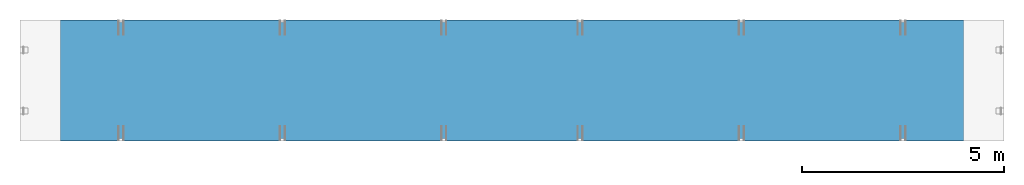
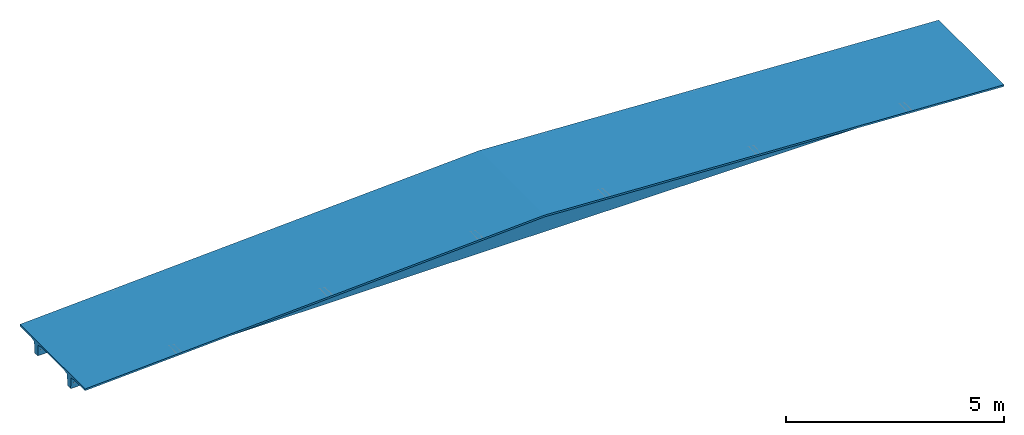
# One storey, part 8 of 8: 1 beam.
"""IFC2X3 building model written with IfcOpenShell, lengths in millimetres."""

from ifc_helpers import new_model, si_unit, frame, origin_with_axes, place, context, subcontext, project, spatial, faceted_brep, material, type_object, element, save


model = new_model("IFC2X3")

# Units and contexts
model_context = context("Model", 3, precision=1e-05, world=origin_with_axes())
body_context = subcontext(model_context, "Body", "Model", "MODEL_VIEW")
ifc_project = project(units=[si_unit("LENGTHUNIT", "METRE", prefix="MILLI"), si_unit("AREAUNIT", "SQUARE_METRE"), si_unit("VOLUMEUNIT", "CUBIC_METRE"), si_unit("MASSUNIT", "GRAM", prefix="KILO"), si_unit("TIMEUNIT", "SECOND"), si_unit("PLANEANGLEUNIT", "RADIAN"), si_unit("SOLIDANGLEUNIT", "STERADIAN"), si_unit("THERMODYNAMICTEMPERATUREUNIT", "DEGREE_CELSIUS"), si_unit("LUMINOUSINTENSITYUNIT", "LUMEN")], contexts=[model_context])

# Site, building, storey
site_placement = place(None, origin_with_axes())
site = spatial("IfcSite", under=ifc_project, at=site_placement, CompositionType="ELEMENT")
building_placement = place(site_placement, origin_with_axes())
building = spatial("IfcBuilding", under=site, at=building_placement, Name="Undefined", CompositionType="ELEMENT")
storey_placement = place(building_placement, origin_with_axes())
storey = spatial("IfcBuildingStorey", under=building, at=storey_placement, Name="Undefined", CompositionType="ELEMENT", Elevation=0.0)

# Beam
ifc_material = material(Name="CONCRETE/Concrete_Undefined")
beam_type = type_object("IfcBeamType", Name="HTT391.25", PredefinedType="NOTDEFINED")
beam_placement = place(storey_placement, frame((5.27828387121526e-14, -3.27270430338636e-13, 500.0), z_axis=(0.0, 0.0, 1.0), x_axis=(1.0, 0.0, 0.0)))
element("IfcBeam", 1, at=beam_placement, inside=storey, type_object=beam_type, material=ifc_material, ObjectType="HTT391.25", context=body_context, shape_type="Brep", body=[
    faceted_brep([(90.8253175473053, 837.75, -343.75), (90.8253175473053, 674.25, -343.75), (86.2499999999998, 674.066987298108, -339.174682452695), (86.2499999999998, 837.933012701892, -339.174682452695), (79.9999999999998, 674.0, -337.5), (79.9999999999998, 838.0, -337.5), (73.7499999999998, 674.066987298108, -339.174682452695), (73.7499999999998, 837.933012701892, -339.174682452695), (69.1746824526943, 674.25, -343.75), (69.1746824526943, 837.75, -343.75), (67.4999999999998, 674.5, -350.0), (67.4999999999998, 837.5, -350.0), (69.1746824526943, 674.75, -356.25), (69.1746824526943, 837.25, -356.25), (73.7499999999998, 674.933012701892, -360.825317547306), (73.7499999999998, 837.066987298108, -360.825317547306), (79.9999999999998, 675.0, -362.5), (79.9999999999998, 837.0, -362.5), (86.2499999999998, 674.933012701892, -360.825317547306), (86.2499999999998, 837.066987298108, -360.825317547306), (90.8253175473053, 674.75, -356.25), (90.8253175473053, 837.25, -356.25), (92.4999999999998, 674.5, -350.0), (92.4999999999998, 837.5, -350.0), (12175.0, 680.5, -500.0), (12175.0, 831.5, -500.0), (24350.0, 831.5, -500.0), (24350.0, 680.5, -500.0), (0.0, 680.5, -500.0), (0.0, 831.5, -500.0), (0.0, 843.65, -196.25), (12175.0, 868.0, 412.5), (0.0, 993.65, -158.75), (12175.0, 1018.0, 450.0), (24350.0, 993.65, -158.75), (24350.0, 843.65, -196.25), (12175.0, 1495.0, 450.0), (24350.0, 1495.0, -158.75), (0.0, 1495.0, -158.75), (0.0, 1495.0, -108.75), (12175.0, 1495.0, 500.0), (24350.0, 1495.0, -108.75), (12175.0, -1495.0, 500.0), (24350.0, -1495.0, -108.75), (0.0, -1495.0, -108.75), (12175.0, -831.5, -500.0), (12175.0, -680.5, -500.0), (24350.0, -680.5, -500.0), (24350.0, -831.5, -500.0), (0.0, -831.5, -500.0), (0.0, -680.5, -500.0), (0.0, -518.35, -158.75), (0.0, 518.35, -158.75), (12175.0, 494.0, 450.0), (12175.0, -494.0, 450.0), (0.0, -668.35, -196.25), (12175.0, -644.0, 412.5), (86.2499999999998, -674.066987298108, -339.174682452695), (79.9999999999998, -674.0, -337.5), (73.7499999999998, -674.066987298108, -339.174682452695), (69.1746824526943, -674.25, -343.75), (67.4999999999998, -674.5, -350.0), (69.1746824526943, -674.75, -356.25), (73.7499999999998, -674.933012701892, -360.825317547306), (79.9999999999998, -675.0, -362.5), (86.2499999999998, -674.933012701892, -360.825317547306), (90.8253175473053, -674.75, -356.25), (92.4999999999998, -674.5, -350.0), (90.8253175473053, -674.25, -343.75), (86.2499999999998, -837.066987298108, -360.825317547306), (90.8253175473053, -837.25, -356.25), (79.9999999999998, -837.0, -362.5), (73.7499999999998, -837.066987298108, -360.825317547306), (69.1746824526943, -837.25, -356.25), (67.4999999999998, -837.5, -350.0), (69.1746824526943, -837.75, -343.75), (73.7499999999998, -837.933012701892, -339.174682452695), (79.9999999999998, -838.0, -337.5), (86.2499999999998, -837.933012701892, -339.174682452695), (90.8253175473053, -837.75, -343.75), (92.4999999999998, -837.5, -350.0), (0.0, -843.65, -196.25), (12175.0, -868.0, 412.5), (0.0, -993.65, -158.75), (12175.0, -1018.0, 450.0), (0.0, -1495.0, -158.75), (12175.0, -1495.0, 450.0), (0.0, 668.35, -196.25), (12175.0, 644.0, 412.5), (24350.0, 668.35, -196.25), (24350.0, 518.35, -158.75), (24350.0, -518.35, -158.75), (24350.0, -668.35, -196.25), (24276.25, -674.066987298108, -339.174682452695), (24270.0, -674.0, -337.5), (24263.75, -674.066987298108, -339.174682452695), (24259.1746824527, -674.25, -343.75), (24257.5, -674.5, -350.0), (24259.1746824527, -674.75, -356.25), (24263.75, -674.933012701892, -360.825317547306), (24270.0, -675.0, -362.5), (24276.25, -674.933012701892, -360.825317547306), (24280.8253175473, -674.75, -356.25), (24282.5, -674.5, -350.0), (24280.8253175473, -674.25, -343.75), (24276.25, -837.066987298108, -360.825317547306), (24280.8253175473, -837.25, -356.25), (24270.0, -837.0, -362.5), (24263.75, -837.066987298108, -360.825317547306), (24259.1746824527, -837.25, -356.25), (24257.5, -837.5, -350.0), (24259.1746824527, -837.75, -343.75), (24263.75, -837.933012701892, -339.174682452695), (24270.0, -838.0, -337.5), (24276.25, -837.933012701892, -339.174682452695), (24280.8253175473, -837.75, -343.75), (24282.5, -837.5, -350.0), (24350.0, -843.65, -196.25), (24350.0, -993.65, -158.75), (24350.0, -1495.0, -158.75), (24276.25, 837.933012701892, -339.174682452695), (24270.0, 838.0, -337.500000000001), (24263.75, 837.933012701892, -339.174682452695), (24259.1746824527, 837.75, -343.750000000001), (24257.5, 837.5, -350.000000000001), (24259.1746824527, 837.25, -356.250000000001), (24263.75, 837.066987298108, -360.825317547306), (24270.0, 837.0, -362.500000000001), (24276.25, 837.066987298108, -360.825317547306), (24280.8253175473, 837.25, -356.250000000001), (24282.5, 837.5, -350.000000000001), (24280.8253175473, 837.75, -343.750000000001), (24276.25, 674.933012701892, -360.825317547306), (24280.8253175473, 674.75, -356.250000000001), (24270.0, 675.0, -362.500000000001), (24263.75, 674.933012701892, -360.825317547306), (24259.1746824527, 674.75, -356.250000000001), (24257.5, 674.5, -350.000000000001), (24259.1746824527, 674.25, -343.750000000001), (24263.75, 674.066987298108, -339.174682452695), (24270.0, 674.0, -337.500000000001), (24276.25, 674.066987298108, -339.174682452695), (24280.8253175473, 674.25, -343.750000000001), (24282.5, 674.5, -350.000000000001)], [[[0, 1, 2, 3]], [[3, 2, 4, 5]], [[5, 4, 6, 7]], [[7, 6, 8, 9]], [[9, 8, 10, 11]], [[11, 10, 12, 13]], [[13, 12, 14, 15]], [[15, 14, 16, 17]], [[17, 16, 18, 19]], [[19, 18, 20, 21]], [[21, 20, 22, 23]], [[23, 22, 1, 0]], [[24, 25, 26, 27]], [[28, 29, 25, 24]], [[29, 30, 31, 25], [3, 5, 7, 9, 11, 13, 15, 17, 19, 21, 23, 0]], [[30, 32, 33, 31]], [[31, 33, 34, 35]], [[33, 36, 37, 34]], [[32, 38, 36, 33]], [[38, 39, 40, 36]], [[36, 40, 41, 37]], [[40, 42, 43, 41]], [[39, 44, 42, 40]], [[45, 46, 47, 48]], [[49, 50, 46, 45]], [[51, 52, 53, 54]], [[55, 51, 54, 56]], [[50, 55, 56, 46], [57, 58, 59, 60, 61, 62, 63, 64, 65, 66, 67, 68]], [[65, 69, 70, 66]], [[64, 71, 69, 65]], [[63, 72, 71, 64]], [[62, 73, 72, 63]], [[61, 74, 73, 62]], [[60, 75, 74, 61]], [[59, 76, 75, 60]], [[58, 77, 76, 59]], [[57, 78, 77, 58]], [[68, 79, 78, 57]], [[67, 80, 79, 68]], [[66, 70, 80, 67]], [[81, 49, 45, 82], [69, 71, 72, 73, 74, 75, 76, 77, 78, 79, 80, 70]], [[83, 81, 82, 84]], [[85, 83, 84, 86]], [[44, 85, 86, 42]], [[39, 38, 32, 30, 29, 28, 87, 52, 51, 55, 50, 49, 81, 83, 85, 44]], [[52, 87, 88, 53]], [[53, 88, 89, 90]], [[54, 53, 90, 91]], [[56, 54, 91, 92]], [[46, 56, 92, 47], [93, 94, 95, 96, 97, 98, 99, 100, 101, 102, 103, 104]], [[101, 105, 106, 102]], [[100, 107, 105, 101]], [[99, 108, 107, 100]], [[98, 109, 108, 99]], [[97, 110, 109, 98]], [[96, 111, 110, 97]], [[95, 112, 111, 96]], [[94, 113, 112, 95]], [[93, 114, 113, 94]], [[104, 115, 114, 93]], [[103, 116, 115, 104]], [[102, 106, 116, 103]], [[82, 45, 48, 117], [105, 107, 108, 109, 110, 111, 112, 113, 114, 115, 116, 106]], [[84, 82, 117, 118]], [[86, 84, 118, 119]], [[42, 86, 119, 43]], [[118, 117, 48, 47, 92, 91, 90, 89, 27, 26, 35, 34, 37, 41, 43, 119]], [[25, 31, 35, 26], [120, 121, 122, 123, 124, 125, 126, 127, 128, 129, 130, 131]], [[128, 132, 133, 129]], [[127, 134, 132, 128]], [[126, 135, 134, 127]], [[125, 136, 135, 126]], [[124, 137, 136, 125]], [[123, 138, 137, 124]], [[122, 139, 138, 123]], [[121, 140, 139, 122]], [[120, 141, 140, 121]], [[131, 142, 141, 120]], [[130, 143, 142, 131]], [[129, 133, 143, 130]], [[88, 24, 27, 89], [132, 134, 135, 136, 137, 138, 139, 140, 141, 142, 143, 133]], [[87, 28, 24, 88], [18, 16, 14, 12, 10, 8, 6, 4, 2, 1, 22, 20]]]),
])

save(model, "model.ifc")
